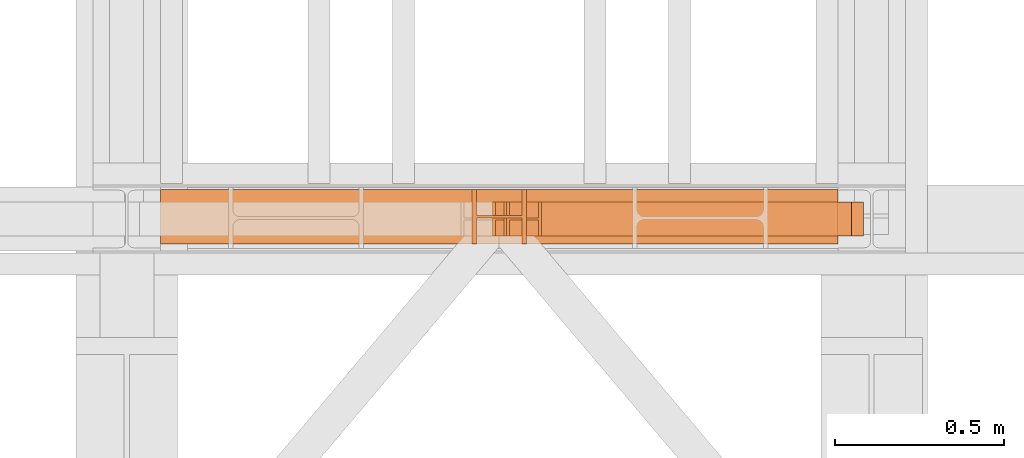
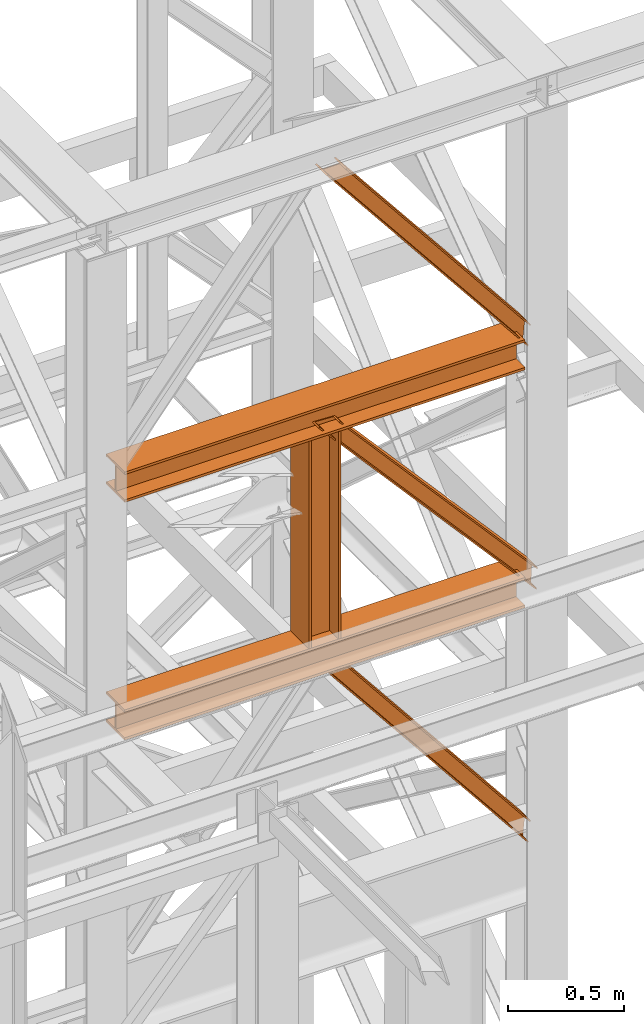
# One storey, part 178 of 208: 6 proxies.
"""IFC2X3 building model written with IfcOpenShell, lengths in millimetres."""

from ifc_helpers import new_model, entity, si_unit, converted_unit, frame, origin, origin_with_axes, place, context, subcontext, project, spatial, faceted_brep, element, save


model = new_model("IFC2X3")

# Units and contexts
model_context = context("Model", 3, precision=1e-05, world=origin())
plan_context = context("Plan", 3, precision=1e-05, world=origin())
body_context = subcontext(model_context, "Body", "Model", "MODEL_VIEW")
ifc_project = project(units=[si_unit("LENGTHUNIT", "METRE", prefix="MILLI"), converted_unit("PLANEANGLEUNIT", "DEGREE", entity("IfcPlaneAngleMeasure", 0.0174532925199433), si_unit("PLANEANGLEUNIT", "RADIAN"), dimensions=[0, 0, 0, 0, 0, 0, 0]), si_unit("AREAUNIT", "SQUARE_METRE"), si_unit("VOLUMEUNIT", "CUBIC_METRE")], contexts=[model_context, plan_context])

# Building, storey
building_placement = place(None, origin())
building = spatial("IfcBuilding", under=ifc_project, at=building_placement, CompositionType="COMPLEX")
storey_placement = place(building_placement, origin_with_axes())
storey = spatial("IfcBuildingStorey", under=building, at=storey_placement, Name="Geschoss", CompositionType="ELEMENT")

# Proxies
proxy_1_placement = place(storey_placement, frame((7714.871371898603, -16012.57439031789, 10993.33854949761), z_axis=(0.0, 0.0, 1.0), x_axis=(1.0, 0.0, 0.0)))
element("IfcBuildingElementProxy", 1, at=proxy_1_placement, inside=storey, context=body_context, shape_type="Brep", body=[
    faceted_brep([(0.01000000000021828, 100.0100000000002, 1256.661509196198), (1007.460542935211, 100.0100000000039, 0.00999999999839929), (1008.388575669588, 100.0100000000039, 9.64798844985853), (8.665826134405506, 100.0100000000002, 1256.661509196198), (0.01000000000021828, 0.01000000000021828, 1256.661509196198), (1007.460542935211, 0.01000000000385626, 0.00999999999839929), (1007.460542935211, 100.0100000000039, 0.00999999999839929), (0.01000000000021828, 100.0100000000002, 1256.661509196198), (8.665826134405506, 0.01000000000021828, 1256.661509196196), (1008.388575669588, 0.01000000000385626, 9.64798844985853), (1007.460542935211, 0.01000000000385626, 0.00999999999839929), (0.01000000000021828, 0.01000000000021828, 1256.661509196198), (8.665826134405506, 47.51000000000022, 1256.661509196196), (1008.388575669588, 47.51000000000386, 9.64798844985853), (1008.388575669588, 0.01000000000385626, 9.64798844985853), (8.665826134405506, 0.01000000000021828, 1256.661509196196), (95.22410068014506, 47.51000000000022, 1256.661509196199), (1017.668903013347, 47.51000000000386, 106.0278729484526), (1008.388575669588, 47.51000000000386, 9.64798844985853), (8.665826134405506, 47.51000000000022, 1256.661509196196), (95.22410068014142, 0.01000000000021828, 1256.661509196198), (1017.668903013345, 0.01000000000385626, 106.0278729484526), (1017.668903013347, 47.51000000000386, 106.0278729484526), (95.22410068014506, 47.51000000000022, 1256.661509196199), (103.8799295906583, 0.01000000000021828, 1256.661509196198), (1018.596935747723, 0.01000000000385626, 115.6658613983127), (1017.668903013345, 0.01000000000385626, 106.0278729484526), (95.22410068014142, 0.01000000000021828, 1256.661509196198), (103.8799295906611, 100.0100000000002, 1256.661509196198), (1018.596935747723, 100.0100000000039, 115.6658613983127), (1018.596935747723, 0.01000000000385626, 115.6658613983127), (103.8799295906583, 0.01000000000021828, 1256.661509196198), (95.22410068014142, 100.0100000000002, 1256.661509196198), (1017.668903013347, 100.0100000000039, 106.0278729484526), (1018.596935747723, 100.0100000000039, 115.6658613983127), (103.8799295906611, 100.0100000000002, 1256.661509196198), (95.2241006801396, 52.51000000000022, 1256.661509196198), (1017.668903013347, 52.51000000000386, 106.0278729484526), (1017.668903013347, 100.0100000000039, 106.0278729484526), (95.22410068014142, 100.0100000000002, 1256.661509196198), (8.665826134405506, 52.51000000000022, 1256.661509196198), (1008.388575669588, 52.51000000000386, 9.64798844985853), (1017.668903013347, 52.51000000000386, 106.0278729484526), (95.2241006801396, 52.51000000000022, 1256.661509196198), (8.665826134405506, 100.0100000000002, 1256.661509196198), (1008.388575669588, 100.0100000000039, 9.64798844985853), (1008.388575669588, 52.51000000000386, 9.64798844985853), (8.665826134405506, 52.51000000000022, 1256.661509196198), (1007.460542935211, 100.0100000000039, 0.00999999999839929), (1007.460542935211, 0.01000000000385626, 0.00999999999839929), (1008.388575669588, 0.01000000000385626, 9.64798844985853), (1008.388575669588, 47.51000000000386, 9.64798844985853), (1017.668903013347, 47.51000000000386, 106.0278729484526), (1017.668903013345, 0.01000000000385626, 106.0278729484526), (1018.596935747723, 0.01000000000385626, 115.6658613983127), (1018.596935747723, 100.0100000000039, 115.6658613983127), (1017.668903013347, 100.0100000000039, 106.0278729484526), (1017.668903013347, 52.51000000000386, 106.0278729484526), (1008.388575669588, 52.51000000000386, 9.64798844985853), (1008.388575669588, 100.0100000000039, 9.64798844985853), (8.665826134405506, 100.0100000000002, 1256.661509196198), (8.665826134405506, 52.51000000000022, 1256.661509196198), (95.2241006801396, 52.51000000000022, 1256.661509196198), (95.22410068014142, 100.0100000000002, 1256.661509196198), (103.8799295906611, 100.0100000000002, 1256.661509196198), (103.8799295906583, 0.01000000000021828, 1256.661509196198), (95.22410068014142, 0.01000000000021828, 1256.661509196198), (95.22410068014506, 47.51000000000022, 1256.661509196199), (8.665826134405506, 47.51000000000022, 1256.661509196196), (8.665826134405506, 0.01000000000021828, 1256.661509196196), (0.01000000000021828, 0.01000000000021828, 1256.661509196198), (0.01000000000021828, 100.0100000000002, 1256.661509196198)], [[[0, 1, 2, 3]], [[4, 5, 6, 7]], [[8, 9, 10, 11]], [[12, 13, 14, 15]], [[16, 17, 18, 19]], [[20, 21, 22, 23]], [[24, 25, 26, 27]], [[28, 29, 30, 31]], [[32, 33, 34, 35]], [[36, 37, 38, 39]], [[40, 41, 42, 43]], [[44, 45, 46, 47]], [[48, 49, 50, 51, 52, 53, 54, 55, 56, 57, 58, 59]], [[60, 61, 62, 63, 64, 65, 66, 67, 68, 69, 70, 71]]], orient=[[False], [False], [False], [False], [False], [False], [False], [False], [False], [False], [False], [False], [False], [False]]),
])
proxy_2_placement = place(storey_placement, frame((7673.060281099813, -16012.57439031789, 9695.192903627512), z_axis=(0.0, 0.0, 1.0), x_axis=(1.0, 0.0, 0.0)))
element("IfcBuildingElementProxy", 2, at=proxy_2_placement, inside=storey, context=body_context, shape_type="Brep", body=[
    faceted_brep([(0.01000000000021828, 100.0100000000002, 1235.79842670739), (1090.249364510873, 100.0100000000039, 0.01000000000021828), (1090.722355585021, 100.0100000000039, 9.681005405827818), (9.422127219051617, 100.0100000000002, 1235.33809688888), (0.01000000000021828, 0.01000000000021828, 1235.79842670739), (1090.249364510873, 0.01000000000385626, 0.01000000000021828), (1090.249364510873, 100.0100000000039, 0.01000000000021828), (0.01000000000021828, 100.0100000000002, 1235.79842670739), (9.422127219051617, 0.01000000000021828, 1235.33809688888), (1090.722355585021, 0.01000000000385626, 9.681005405827818), (1090.249364510873, 0.01000000000385626, 0.01000000000021828), (0.01000000000021828, 0.01000000000021828, 1235.79842670739), (9.422127219051617, 47.51000000000022, 1235.33809688888), (1090.722355585021, 47.51000000000386, 9.681005405827818), (1090.722355585021, 0.01000000000385626, 9.681005405827818), (9.422127219051617, 0.01000000000021828, 1235.33809688888), (103.5433994095747, 47.51000000000022, 1230.73479870369), (1095.4522663265, 47.51000000000386, 106.3910594640602), (1090.722355585021, 47.51000000000386, 9.681005405827818), (9.422127219051617, 47.51000000000022, 1235.33809688888), (103.5433994095711, 0.01000000000021828, 1230.73479870369), (1095.452266326498, 0.01000000000385626, 106.3910594640602), (1095.4522663265, 47.51000000000386, 106.3910594640602), (103.5433994095747, 47.51000000000022, 1230.73479870369), (112.9555266286243, 0.01000000000021828, 1230.274468885165), (1095.925257400648, 0.01000000000385626, 116.0620648698878), (1095.452266326498, 0.01000000000385626, 106.3910594640602), (103.5433994095711, 0.01000000000021828, 1230.73479870369), (112.9555266286279, 100.0100000000002, 1230.274468885173), (1095.925257400648, 100.0100000000039, 116.0620648698878), (1095.925257400648, 0.01000000000385626, 116.0620648698878), (112.9555266286243, 0.01000000000021828, 1230.274468885165), (103.5433994095711, 100.0100000000002, 1230.73479870369), (1095.4522663265, 100.0100000000039, 106.3910594640602), (1095.925257400648, 100.0100000000039, 116.0620648698878), (112.9555266286279, 100.0100000000002, 1230.274468885173), (103.5433994095693, 52.51000000000022, 1230.73479870369), (1095.4522663265, 52.51000000000386, 106.3910594640602), (1095.4522663265, 100.0100000000039, 106.3910594640602), (103.5433994095711, 100.0100000000002, 1230.73479870369), (9.422127219051617, 52.51000000000022, 1235.33809688888), (1090.722355585021, 52.51000000000386, 9.681005405827818), (1095.4522663265, 52.51000000000386, 106.3910594640602), (103.5433994095693, 52.51000000000022, 1230.73479870369), (9.422127219051617, 100.0100000000002, 1235.33809688888), (1090.722355585021, 100.0100000000039, 9.681005405827818), (1090.722355585021, 52.51000000000386, 9.681005405827818), (9.422127219051617, 52.51000000000022, 1235.33809688888), (1090.249364510873, 100.0100000000039, 0.01000000000021828), (1090.249364510873, 0.01000000000385626, 0.01000000000021828), (1090.722355585021, 0.01000000000385626, 9.681005405827818), (1090.722355585021, 47.51000000000386, 9.681005405827818), (1095.4522663265, 47.51000000000386, 106.3910594640602), (1095.452266326498, 0.01000000000385626, 106.3910594640602), (1095.925257400648, 0.01000000000385626, 116.0620648698878), (1095.925257400648, 100.0100000000039, 116.0620648698878), (1095.4522663265, 100.0100000000039, 106.3910594640602), (1095.4522663265, 52.51000000000386, 106.3910594640602), (1090.722355585021, 52.51000000000386, 9.681005405827818), (1090.722355585021, 100.0100000000039, 9.681005405827818), (9.422127219051617, 100.0100000000002, 1235.33809688888), (9.422127219051617, 52.51000000000022, 1235.33809688888), (103.5433994095693, 52.51000000000022, 1230.73479870369), (103.5433994095711, 100.0100000000002, 1230.73479870369), (112.9555266286279, 100.0100000000002, 1230.274468885173), (112.9555266286243, 0.01000000000021828, 1230.274468885165), (103.5433994095711, 0.01000000000021828, 1230.73479870369), (103.5433994095747, 47.51000000000022, 1230.73479870369), (9.422127219051617, 47.51000000000022, 1235.33809688888), (9.422127219051617, 0.01000000000021828, 1235.33809688888), (0.01000000000021828, 0.01000000000021828, 1235.79842670739), (0.01000000000021828, 100.0100000000002, 1235.79842670739)], [[[0, 1, 2, 3]], [[4, 5, 6, 7]], [[8, 9, 10, 11]], [[12, 13, 14, 15]], [[16, 17, 18, 19]], [[20, 21, 22, 23]], [[24, 25, 26, 27]], [[28, 29, 30, 31]], [[32, 33, 34, 35]], [[36, 37, 38, 39]], [[40, 41, 42, 43]], [[44, 45, 46, 47]], [[48, 49, 50, 51, 52, 53, 54, 55, 56, 57, 58, 59]], [[60, 61, 62, 63, 64, 65, 66, 67, 68, 69, 70, 71]]], orient=[[False], [False], [False], [False], [False], [False], [False], [False], [False], [False], [False], [False], [False], [False]]),
])
proxy_3_placement = place(storey_placement, frame((7706.85521291981, -16012.57439031789, 8372.338544133194), z_axis=(0.0, 0.0, 1.0), x_axis=(1.0, 0.0, 0.0)))
element("IfcBuildingElementProxy", 3, at=proxy_3_placement, inside=storey, context=body_context, shape_type="Brep", body=[
    faceted_brep([(0.01000000000112777, 100.0100000000002, 1266.66151456061), (1015.476701914005, 100.0100000000039, 0.01000000000021828), (1016.404734648381, 100.0100000000039, 9.64798844986035), (8.665774577697448, 100.0100000000002, 1266.66151456061), (0.01000000000112777, 0.01000000000021828, 1266.66151456061), (1015.476701914005, 0.01000000000385626, 0.01000000000021828), (1015.476701914005, 100.0100000000039, 0.01000000000021828), (0.01000000000112777, 100.0100000000002, 1266.66151456061), (8.665774577697448, 0.01000000000021828, 1266.66151456061), (1016.404734648381, 0.01000000000385626, 9.64798844986035), (1015.476701914005, 0.01000000000385626, 0.01000000000021828), (0.01000000000112777, 0.01000000000021828, 1266.66151456061), (8.665774577697448, 47.51000000000022, 1266.66151456061), (1016.404734648381, 47.51000000000386, 9.64798844986035), (1016.404734648381, 0.01000000000385626, 9.64798844986035), (8.665774577697448, 0.01000000000021828, 1266.66151456061), (95.22348536426489, 47.51000000000022, 1266.66151456061), (1025.68506199214, 47.51000000000386, 106.0278729484544), (1016.404734648381, 47.51000000000386, 9.64798844986035), (8.665774577697448, 47.51000000000022, 1266.66151456061), (95.22348536426125, 0.01000000000021828, 1266.66151456061), (1025.685061992138, 0.01000000000385626, 106.0278729484544), (1025.68506199214, 47.51000000000386, 106.0278729484544), (95.22348536426489, 47.51000000000022, 1266.66151456061), (103.879252584019, 0.01000000000021828, 1266.66151456061), (1026.613094726517, 0.01000000000385626, 115.6658613983145), (1025.685061992138, 0.01000000000385626, 106.0278729484544), (95.22348536426125, 0.01000000000021828, 1266.66151456061), (103.8792525840227, 100.0100000000002, 1266.66151456061), (1026.613094726517, 100.0100000000039, 115.6658613983145), (1026.613094726517, 0.01000000000385626, 115.6658613983145), (103.879252584019, 0.01000000000021828, 1266.66151456061), (95.22348536426125, 100.0100000000002, 1266.66151456061), (1025.68506199214, 100.0100000000039, 106.0278729484544), (1026.613094726517, 100.0100000000039, 115.6658613983145), (103.8792525840227, 100.0100000000002, 1266.66151456061), (95.22348536426034, 52.51000000000022, 1266.66151456061), (1025.68506199214, 52.51000000000386, 106.0278729484544), (1025.68506199214, 100.0100000000039, 106.0278729484544), (95.22348536426125, 100.0100000000002, 1266.66151456061), (8.665774577697448, 52.51000000000022, 1266.66151456061), (1016.404734648381, 52.51000000000386, 9.64798844986035), (1025.68506199214, 52.51000000000386, 106.0278729484544), (95.22348536426034, 52.51000000000022, 1266.66151456061), (8.665774577697448, 100.0100000000002, 1266.66151456061), (1016.404734648381, 100.0100000000039, 9.64798844986035), (1016.404734648381, 52.51000000000386, 9.64798844986035), (8.665774577697448, 52.51000000000022, 1266.66151456061), (1015.476701914005, 100.0100000000039, 0.01000000000021828), (1015.476701914005, 0.01000000000385626, 0.01000000000021828), (1016.404734648381, 0.01000000000385626, 9.64798844986035), (1016.404734648381, 47.51000000000386, 9.64798844986035), (1025.68506199214, 47.51000000000386, 106.0278729484544), (1025.685061992138, 0.01000000000385626, 106.0278729484544), (1026.613094726517, 0.01000000000385626, 115.6658613983145), (1026.613094726517, 100.0100000000039, 115.6658613983145), (1025.68506199214, 100.0100000000039, 106.0278729484544), (1025.68506199214, 52.51000000000386, 106.0278729484544), (1016.404734648381, 52.51000000000386, 9.64798844986035), (1016.404734648381, 100.0100000000039, 9.64798844986035), (8.665774577697448, 100.0100000000002, 1266.66151456061), (8.665774577697448, 52.51000000000022, 1266.66151456061), (95.22348536426034, 52.51000000000022, 1266.66151456061), (95.22348536426125, 100.0100000000002, 1266.66151456061), (103.8792525840227, 100.0100000000002, 1266.66151456061), (103.879252584019, 0.01000000000021828, 1266.66151456061), (95.22348536426125, 0.01000000000021828, 1266.66151456061), (95.22348536426489, 47.51000000000022, 1266.66151456061), (8.665774577697448, 47.51000000000022, 1266.66151456061), (8.665774577697448, 0.01000000000021828, 1266.66151456061), (0.01000000000112777, 0.01000000000021828, 1266.66151456061), (0.01000000000112777, 100.0100000000002, 1266.66151456061)], [[[0, 1, 2, 3]], [[4, 5, 6, 7]], [[8, 9, 10, 11]], [[12, 13, 14, 15]], [[16, 17, 18, 19]], [[20, 21, 22, 23]], [[24, 25, 26, 27]], [[28, 29, 30, 31]], [[32, 33, 34, 35]], [[36, 37, 38, 39]], [[40, 41, 42, 43]], [[44, 45, 46, 47]], [[48, 49, 50, 51, 52, 53, 54, 55, 56, 57, 58, 59]], [[60, 61, 62, 63, 64, 65, 66, 67, 68, 69, 70, 71]]], orient=[[False], [False], [False], [False], [False], [False], [False], [False], [False], [False], [False], [False], [False], [False]]),
])
proxy_4_placement = place(storey_placement, frame((7613.254968528666, -16036.07439031789, 9798.990058693804), z_axis=(0.0, 0.0, 1.0), x_axis=(1.0, 0.0, 0.0)))
element("IfcBuildingElementProxy", 4, at=proxy_4_placement, inside=storey, context=body_context, shape_type="Brep", body=[
    faceted_brep([(0.01000000000021828, 160.0100000000002, 1096.01), (0.01000000000112777, 160.0100000000002, 0.01000000000021828), (13.01000000000113, 160.0100000000002, 0.01000000000021828), (13.01000000000022, 160.0100000000002, 1096.01), (13.01000000000022, 160.0100000000002, 1096.01), (13.01000000000113, 160.0100000000002, 0.01000000000021828), (13.01000000000113, 84.01000000000022, 0.01000000000021828), (13.01000000000022, 84.01000000000022, 1096.01), (13.01000000000022, 84.01000000000022, 1096.01), (13.01000000000113, 84.01000000000022, 0.01000000000021828), (147.0100000000011, 84.01000000000022, 0.01000000000021828), (147.0100000000002, 84.01000000000022, 1096.01), (147.0100000000002, 84.01000000000022, 1096.01), (147.0100000000011, 84.01000000000022, 0.01000000000021828), (147.0100000000011, 160.0100000000002, 0.01000000000021828), (147.0100000000002, 160.0100000000002, 1096.01), (147.0100000000002, 160.0100000000002, 1096.01), (147.0100000000011, 160.0100000000002, 0.01000000000021828), (160.0100000000002, 160.0100000000002, 0.01000000000021828), (160.0100000000002, 160.0100000000002, 1096.01), (160.0100000000002, 160.0100000000002, 1096.01), (160.0100000000002, 160.0100000000002, 0.01000000000021828), (160.0100000000002, 0.01000000000021828, 0.01000000000021828), (160.0100000000002, 0.01000000000021828, 1096.01), (160.0100000000002, 0.01000000000021828, 1096.01), (160.0100000000002, 0.01000000000021828, 0.01000000000021828), (147.0100000000011, 0.01000000000021828, 0.01000000000021828), (147.0100000000002, 0.01000000000021828, 1096.01), (147.0100000000002, 0.01000000000021828, 1096.01), (147.0100000000011, 0.01000000000021828, 0.01000000000021828), (147.0100000000011, 76.01000000000022, 0.01000000000021828), (147.0100000000002, 76.01000000000022, 1096.01), (147.0100000000002, 76.01000000000022, 1096.01), (147.0100000000011, 76.01000000000022, 0.01000000000021828), (13.01000000000113, 76.01000000000022, 0.01000000000021828), (13.01000000000022, 76.01000000000022, 1096.01), (13.01000000000022, 76.01000000000022, 1096.01), (13.01000000000113, 76.01000000000022, 0.01000000000021828), (13.01000000000113, 0.01000000000021828, 0.01000000000021828), (13.01000000000022, 0.01000000000021828, 1096.01), (13.01000000000022, 0.01000000000021828, 1096.01), (13.01000000000113, 0.01000000000021828, 0.01000000000021828), (0.01000000000112777, 0.01000000000021828, 0.01000000000021828), (0.01000000000021828, 0.01000000000021828, 1096.01), (0.01000000000021828, 0.01000000000021828, 1096.01), (0.01000000000112777, 0.01000000000021828, 0.01000000000021828), (0.01000000000112777, 160.0100000000002, 0.01000000000021828), (0.01000000000021828, 160.0100000000002, 1096.01), (0.01000000000021828, 160.0100000000002, 1096.01), (13.01000000000022, 160.0100000000002, 1096.01), (13.01000000000022, 84.01000000000022, 1096.01), (147.0100000000002, 84.01000000000022, 1096.01), (147.0100000000002, 160.0100000000002, 1096.01), (160.0100000000002, 160.0100000000002, 1096.01), (160.0100000000002, 0.01000000000021828, 1096.01), (147.0100000000002, 0.01000000000021828, 1096.01), (147.0100000000002, 76.01000000000022, 1096.01), (13.01000000000022, 76.01000000000022, 1096.01), (13.01000000000022, 0.01000000000021828, 1096.01), (0.01000000000021828, 0.01000000000021828, 1096.01), (0.01000000000112777, 160.0100000000002, 0.01000000000021828), (0.01000000000112777, 0.01000000000021828, 0.01000000000021828), (13.01000000000113, 0.01000000000021828, 0.01000000000021828), (13.01000000000113, 76.01000000000022, 0.01000000000021828), (147.0100000000011, 76.01000000000022, 0.01000000000021828), (147.0100000000011, 0.01000000000021828, 0.01000000000021828), (160.0100000000002, 0.01000000000021828, 0.01000000000021828), (160.0100000000002, 160.0100000000002, 0.01000000000021828), (147.0100000000011, 160.0100000000002, 0.01000000000021828), (147.0100000000011, 84.01000000000022, 0.01000000000021828), (13.01000000000113, 84.01000000000022, 0.01000000000021828), (13.01000000000113, 160.0100000000002, 0.01000000000021828)], [[[0, 1, 2, 3]], [[4, 5, 6, 7]], [[8, 9, 10, 11]], [[12, 13, 14, 15]], [[16, 17, 18, 19]], [[20, 21, 22, 23]], [[24, 25, 26, 27]], [[28, 29, 30, 31]], [[32, 33, 34, 35]], [[36, 37, 38, 39]], [[40, 41, 42, 43]], [[44, 45, 46, 47]], [[48, 49, 50, 51, 52, 53, 54, 55, 56, 57, 58, 59]], [[60, 61, 62, 63, 64, 65, 66, 67, 68, 69, 70, 71]]], orient=[[False], [False], [False], [False], [False], [False], [False], [False], [False], [False], [False], [False], [False], [False]]),
])
proxy_5_placement = place(storey_placement, frame((6693.254970018783, -16036.07439031789, 10894.9900586938), z_axis=(0.0, 0.0, 1.0), x_axis=(1.0, 0.0, 0.0)))
element("IfcBuildingElementProxy", 5, at=proxy_5_placement, inside=storey, context=body_context, shape_type="Brep", body=[
    faceted_brep([(2000.009997019768, 160.0100000000002, 160.0100000000002), (0.009999999999308784, 160.0100000000002, 160.0100000000002), (0.009999999999308784, 160.0100000000002, 147.0100000000002), (2000.009997019768, 160.0100000000002, 147.0100000000002), (2000.009997019768, 160.0100000000002, 147.0100000000002), (0.009999999999308784, 160.0100000000002, 147.0100000000002), (0.009999999999308784, 84.01000000000022, 147.0100000000002), (2000.009997019768, 84.01000000000022, 147.0100000000002), (2000.009997019768, 84.01000000000022, 147.0100000000002), (0.009999999999308784, 84.01000000000022, 147.0100000000002), (0.009999999999308784, 84.01000000000022, 13.01000000000022), (2000.009997019768, 84.01000000000022, 13.01000000000022), (2000.009997019768, 84.01000000000022, 13.01000000000022), (0.009999999999308784, 84.01000000000022, 13.01000000000022), (0.009999999999308784, 160.0100000000002, 13.01000000000022), (2000.009997019768, 160.0100000000002, 13.01000000000022), (2000.009997019768, 160.0100000000002, 13.01000000000022), (0.009999999999308784, 160.0100000000002, 13.01000000000022), (0.009999999999308784, 160.0100000000002, 0.01000000000021828), (2000.009997019768, 160.0100000000002, 0.01000000000021828), (2000.009997019768, 160.0100000000002, 0.01000000000021828), (0.009999999999308784, 160.0100000000002, 0.01000000000021828), (0.009999999999308784, 0.01000000000021828, 0.01000000000021828), (2000.009997019768, 0.01000000000021828, 0.01000000000021828), (2000.009997019768, 0.01000000000021828, 0.01000000000021828), (0.009999999999308784, 0.01000000000021828, 0.01000000000021828), (0.009999999999308784, 0.01000000000021828, 13.01000000000022), (2000.009997019768, 0.01000000000021828, 13.01000000000022), (2000.009997019768, 0.01000000000021828, 13.01000000000022), (0.009999999999308784, 0.01000000000021828, 13.01000000000022), (0.009999999999308784, 76.01000000000022, 13.01000000000022), (2000.009997019768, 76.01000000000022, 13.01000000000022), (2000.009997019768, 76.01000000000022, 13.01000000000022), (0.009999999999308784, 76.01000000000022, 13.01000000000022), (0.009999999999308784, 76.01000000000022, 147.0100000000002), (2000.009997019768, 76.01000000000022, 147.0100000000002), (2000.009997019768, 76.01000000000022, 147.0100000000002), (0.009999999999308784, 76.01000000000022, 147.0100000000002), (0.009999999999308784, 0.01000000000021828, 147.0100000000002), (2000.009997019768, 0.01000000000021828, 147.0100000000002), (2000.009997019768, 0.01000000000021828, 147.0100000000002), (0.009999999999308784, 0.01000000000021828, 147.0100000000002), (0.009999999999308784, 0.01000000000021828, 160.0100000000002), (2000.009997019768, 0.01000000000021828, 160.0100000000002), (2000.009997019768, 0.01000000000021828, 160.0100000000002), (0.009999999999308784, 0.01000000000021828, 160.0100000000002), (0.009999999999308784, 160.0100000000002, 160.0100000000002), (2000.009997019768, 160.0100000000002, 160.0100000000002), (2000.009997019768, 160.0100000000002, 160.0100000000002), (2000.009997019768, 160.0100000000002, 147.0100000000002), (2000.009997019768, 84.01000000000022, 147.0100000000002), (2000.009997019768, 84.01000000000022, 13.01000000000022), (2000.009997019768, 160.0100000000002, 13.01000000000022), (2000.009997019768, 160.0100000000002, 0.01000000000021828), (2000.009997019768, 0.01000000000021828, 0.01000000000021828), (2000.009997019768, 0.01000000000021828, 13.01000000000022), (2000.009997019768, 76.01000000000022, 13.01000000000022), (2000.009997019768, 76.01000000000022, 147.0100000000002), (2000.009997019768, 0.01000000000021828, 147.0100000000002), (2000.009997019768, 0.01000000000021828, 160.0100000000002), (0.009999999999308784, 160.0100000000002, 160.0100000000002), (0.009999999999308784, 0.01000000000021828, 160.0100000000002), (0.009999999999308784, 0.01000000000021828, 147.0100000000002), (0.009999999999308784, 76.01000000000022, 147.0100000000002), (0.009999999999308784, 76.01000000000022, 13.01000000000022), (0.009999999999308784, 0.01000000000021828, 13.01000000000022), (0.009999999999308784, 0.01000000000021828, 0.01000000000021828), (0.009999999999308784, 160.0100000000002, 0.01000000000021828), (0.009999999999308784, 160.0100000000002, 13.01000000000022), (0.009999999999308784, 84.01000000000022, 13.01000000000022), (0.009999999999308784, 84.01000000000022, 147.0100000000002), (0.009999999999308784, 160.0100000000002, 147.0100000000002)], [[[0, 1, 2, 3]], [[4, 5, 6, 7]], [[8, 9, 10, 11]], [[12, 13, 14, 15]], [[16, 17, 18, 19]], [[20, 21, 22, 23]], [[24, 25, 26, 27]], [[28, 29, 30, 31]], [[32, 33, 34, 35]], [[36, 37, 38, 39]], [[40, 41, 42, 43]], [[44, 45, 46, 47]], [[48, 49, 50, 51, 52, 53, 54, 55, 56, 57, 58, 59]], [[60, 61, 62, 63, 64, 65, 66, 67, 68, 69, 70, 71]]], orient=[[False], [False], [False], [False], [False], [False], [False], [False], [False], [False], [False], [False], [False], [False]]),
])
proxy_6_placement = place(storey_placement, frame((6693.254970018783, -16036.07439031789, 9638.990058693804), z_axis=(0.0, 0.0, 1.0), x_axis=(1.0, 0.0, 0.0)))
element("IfcBuildingElementProxy", 6, at=proxy_6_placement, inside=storey, context=body_context, shape_type="Brep", body=[
    faceted_brep([(2000.009997019768, 160.0100000000002, 160.0100000000002), (0.009999999999308784, 160.0100000000002, 160.0100000000002), (0.009999999999308784, 160.0100000000002, 147.0100000000002), (2000.009997019768, 160.0100000000002, 147.0100000000002), (2000.009997019768, 160.0100000000002, 147.0100000000002), (0.009999999999308784, 160.0100000000002, 147.0100000000002), (0.009999999999308784, 84.01000000000022, 147.0100000000002), (2000.009997019768, 84.01000000000022, 147.0100000000002), (2000.009997019768, 84.01000000000022, 147.0100000000002), (0.009999999999308784, 84.01000000000022, 147.0100000000002), (0.009999999999308784, 84.01000000000022, 13.01000000000022), (2000.009997019768, 84.01000000000022, 13.01000000000022), (2000.009997019768, 84.01000000000022, 13.01000000000022), (0.009999999999308784, 84.01000000000022, 13.01000000000022), (0.009999999999308784, 160.0100000000002, 13.01000000000022), (2000.009997019768, 160.0100000000002, 13.01000000000022), (2000.009997019768, 160.0100000000002, 13.01000000000022), (0.009999999999308784, 160.0100000000002, 13.01000000000022), (0.009999999999308784, 160.0100000000002, 0.01000000000021828), (2000.009997019768, 160.0100000000002, 0.01000000000021828), (2000.009997019768, 160.0100000000002, 0.01000000000021828), (0.009999999999308784, 160.0100000000002, 0.01000000000021828), (0.009999999999308784, 0.01000000000021828, 0.01000000000021828), (2000.009997019768, 0.01000000000021828, 0.01000000000021828), (2000.009997019768, 0.01000000000021828, 0.01000000000021828), (0.009999999999308784, 0.01000000000021828, 0.01000000000021828), (0.009999999999308784, 0.01000000000021828, 13.01000000000022), (2000.009997019768, 0.01000000000021828, 13.01000000000022), (2000.009997019768, 0.01000000000021828, 13.01000000000022), (0.009999999999308784, 0.01000000000021828, 13.01000000000022), (0.009999999999308784, 76.01000000000022, 13.01000000000022), (2000.009997019768, 76.01000000000022, 13.01000000000022), (2000.009997019768, 76.01000000000022, 13.01000000000022), (0.009999999999308784, 76.01000000000022, 13.01000000000022), (0.009999999999308784, 76.01000000000022, 147.0100000000002), (2000.009997019768, 76.01000000000022, 147.0100000000002), (2000.009997019768, 76.01000000000022, 147.0100000000002), (0.009999999999308784, 76.01000000000022, 147.0100000000002), (0.009999999999308784, 0.01000000000021828, 147.0100000000002), (2000.009997019768, 0.01000000000021828, 147.0100000000002), (2000.009997019768, 0.01000000000021828, 147.0100000000002), (0.009999999999308784, 0.01000000000021828, 147.0100000000002), (0.009999999999308784, 0.01000000000021828, 160.0100000000002), (2000.009997019768, 0.01000000000021828, 160.0100000000002), (2000.009997019768, 0.01000000000021828, 160.0100000000002), (0.009999999999308784, 0.01000000000021828, 160.0100000000002), (0.009999999999308784, 160.0100000000002, 160.0100000000002), (2000.009997019768, 160.0100000000002, 160.0100000000002), (2000.009997019768, 160.0100000000002, 160.0100000000002), (2000.009997019768, 160.0100000000002, 147.0100000000002), (2000.009997019768, 84.01000000000022, 147.0100000000002), (2000.009997019768, 84.01000000000022, 13.01000000000022), (2000.009997019768, 160.0100000000002, 13.01000000000022), (2000.009997019768, 160.0100000000002, 0.01000000000021828), (2000.009997019768, 0.01000000000021828, 0.01000000000021828), (2000.009997019768, 0.01000000000021828, 13.01000000000022), (2000.009997019768, 76.01000000000022, 13.01000000000022), (2000.009997019768, 76.01000000000022, 147.0100000000002), (2000.009997019768, 0.01000000000021828, 147.0100000000002), (2000.009997019768, 0.01000000000021828, 160.0100000000002), (0.009999999999308784, 160.0100000000002, 160.0100000000002), (0.009999999999308784, 0.01000000000021828, 160.0100000000002), (0.009999999999308784, 0.01000000000021828, 147.0100000000002), (0.009999999999308784, 76.01000000000022, 147.0100000000002), (0.009999999999308784, 76.01000000000022, 13.01000000000022), (0.009999999999308784, 0.01000000000021828, 13.01000000000022), (0.009999999999308784, 0.01000000000021828, 0.01000000000021828), (0.009999999999308784, 160.0100000000002, 0.01000000000021828), (0.009999999999308784, 160.0100000000002, 13.01000000000022), (0.009999999999308784, 84.01000000000022, 13.01000000000022), (0.009999999999308784, 84.01000000000022, 147.0100000000002), (0.009999999999308784, 160.0100000000002, 147.0100000000002)], [[[0, 1, 2, 3]], [[4, 5, 6, 7]], [[8, 9, 10, 11]], [[12, 13, 14, 15]], [[16, 17, 18, 19]], [[20, 21, 22, 23]], [[24, 25, 26, 27]], [[28, 29, 30, 31]], [[32, 33, 34, 35]], [[36, 37, 38, 39]], [[40, 41, 42, 43]], [[44, 45, 46, 47]], [[48, 49, 50, 51, 52, 53, 54, 55, 56, 57, 58, 59]], [[60, 61, 62, 63, 64, 65, 66, 67, 68, 69, 70, 71]]], orient=[[False], [False], [False], [False], [False], [False], [False], [False], [False], [False], [False], [False], [False], [False]]),
])

save(model, "model.ifc")
